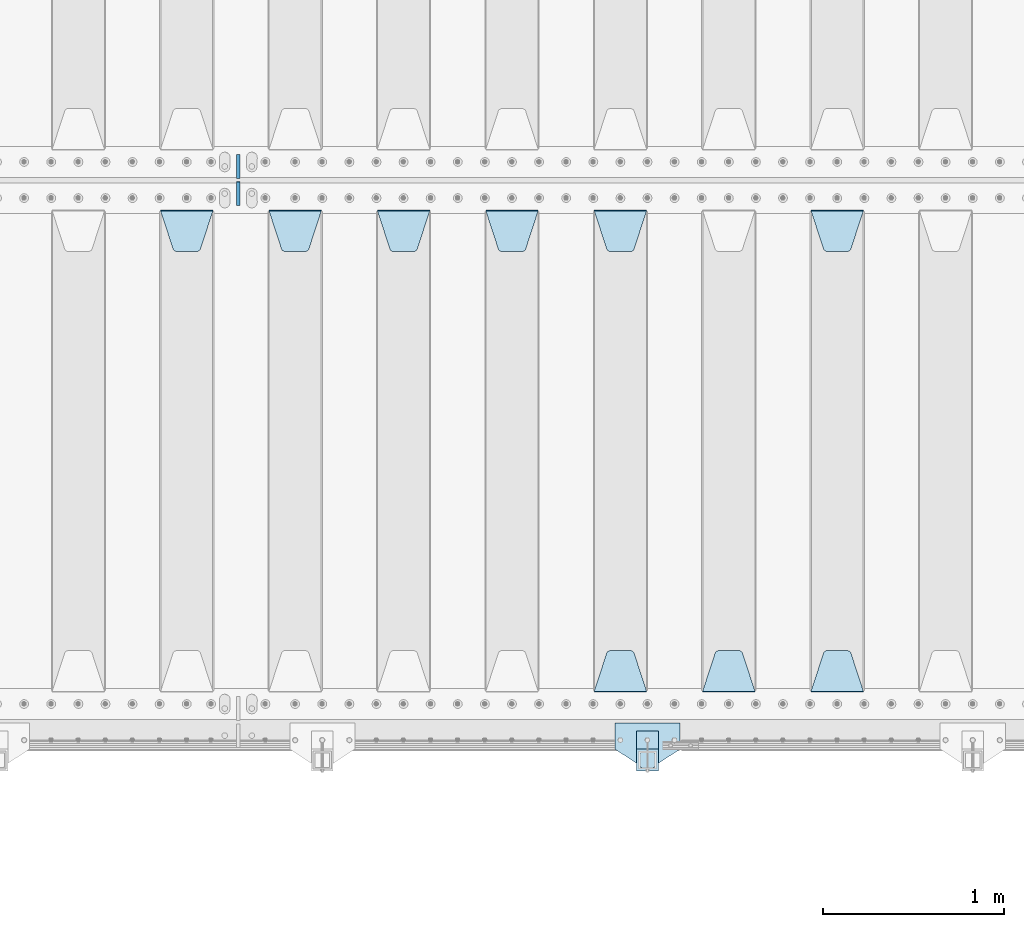
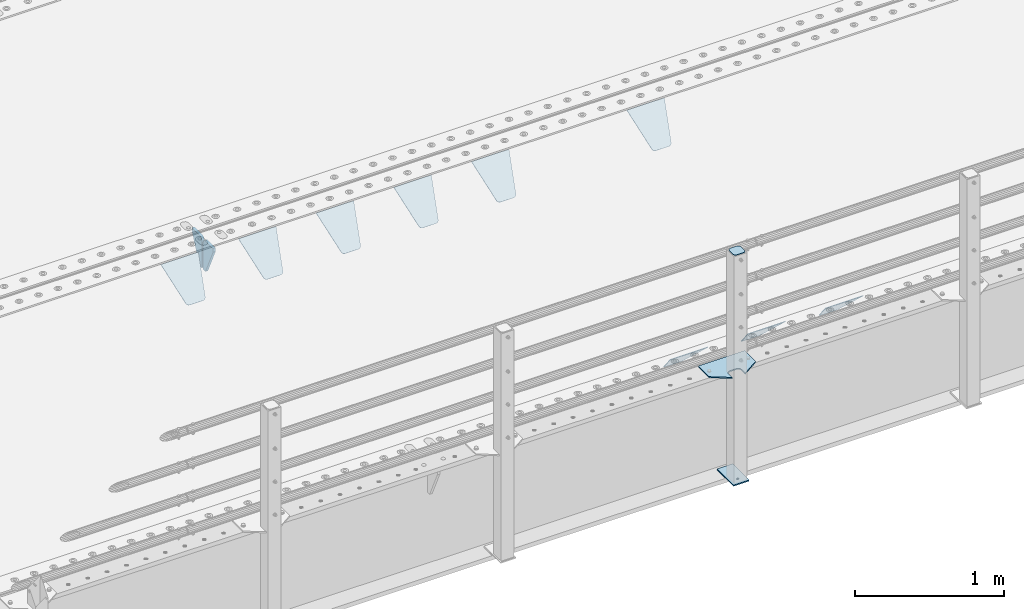
# One storey, part 221 of 270: 15 plates.
"""IFC2X3 building model written with IfcOpenShell, lengths in millimetres."""

from ifc_helpers import new_model, si_unit, frame, origin_with_axes, place, context, subcontext, project, spatial, faceted_brep, material, type_object, element, save


model = new_model("IFC2X3")

# Units and contexts
model_context = context("Model", 3, precision=1e-05, world=origin_with_axes())
body_context = subcontext(model_context, "Body", "Model", "MODEL_VIEW")
ifc_project = project(units=[si_unit("LENGTHUNIT", "METRE", prefix="MILLI"), si_unit("AREAUNIT", "SQUARE_METRE"), si_unit("VOLUMEUNIT", "CUBIC_METRE"), si_unit("MASSUNIT", "GRAM", prefix="KILO"), si_unit("TIMEUNIT", "SECOND"), si_unit("PLANEANGLEUNIT", "RADIAN"), si_unit("SOLIDANGLEUNIT", "STERADIAN"), si_unit("THERMODYNAMICTEMPERATUREUNIT", "DEGREE_CELSIUS"), si_unit("LUMINOUSINTENSITYUNIT", "LUMEN")], contexts=[model_context])

# Site, building, storey
site_placement = place(None, origin_with_axes())
site = spatial("IfcSite", under=ifc_project, at=site_placement, CompositionType="ELEMENT")
building_placement = place(site_placement, origin_with_axes())
building = spatial("IfcBuilding", under=site, at=building_placement, Name="Standard", CompositionType="ELEMENT")
storey_placement = place(building_placement, origin_with_axes())
storey = spatial("IfcBuildingStorey", under=building, at=storey_placement, Name="Undefined", CompositionType="ELEMENT", Elevation=0.0)

# Plates
ifc_material_1 = material(Name="STEEL/S355J2")
plate_type_1 = type_object("IfcPlateType", PredefinedType="NOTDEFINED")
plate_1_placement = place(storey_placement, frame((9730.0, -24005.0, 5.00000000004911), z_axis=(0.0, -1.0, 0.0), x_axis=(-1.0, 0.0, 0.0)))
element("IfcPlate", 1, at=plate_1_placement, inside=storey, type_object=plate_type_1, material=ifc_material_1, context=body_context, shape_type="Brep", body=[
    faceted_brep([(0.0, -5.0, 0.0), (2.31396552408114e-06, -5.0, 145.0), (2.31396552408114e-06, 5.0, 145.0), (0.0, 5.0, 0.0), (130.0, -5.0, 230.0), (130.0, 5.0, 230.0), (130.0, -5.0, 180.0), (130.0, 5.0, 180.0), (130.48036798992, -5.0, 175.122741949597), (130.48036798992, 5.0, 175.122741949597), (131.903011687216, -5.0, 170.432914190873), (131.903011687216, 5.0, 170.432914190873), (134.213259692435, -5.0, 166.11074417451), (134.213259692435, 5.0, 166.11074417451), (137.322330470335, -5.0, 162.322330470337), (137.322330470335, 5.0, 162.322330470337), (141.110744174512, -5.0, 159.213259692437), (141.110744174512, 5.0, 159.213259692437), (145.432914190871, -5.0, 156.903011687218), (145.432914190871, 5.0, 156.903011687218), (150.122741949595, -5.0, 155.48036798992), (150.122741949595, 5.0, 155.48036798992), (155.0, -5.0, 155.0), (155.0, 5.0, 155.0), (205.0, -5.0, 155.0), (205.0, 5.0, 155.0), (209.877258050405, -5.0, 155.48036798992), (209.877258050405, 5.0, 155.48036798992), (214.567085809129, -5.0, 156.903011687218), (214.567085809129, 5.0, 156.903011687218), (218.889255825488, -5.0, 159.213259692437), (218.889255825488, 5.0, 159.213259692437), (222.677669529665, -5.0, 162.322330470337), (222.677669529665, 5.0, 162.322330470337), (225.786740307565, -5.0, 166.11074417451), (225.786740307565, 5.0, 166.11074417451), (228.096988312784, -5.0, 170.432914190873), (228.096988312784, 5.0, 170.432914190873), (229.51963201008, -5.0, 175.122741949597), (229.51963201008, 5.0, 175.122741949597), (230.0, -5.0, 180.0), (230.0, 5.0, 180.0), (230.0, -5.0, 230.0), (230.0, 5.0, 230.0), (360.0, -5.0, 145.0), (360.0, 5.0, 145.0), (360.0, -5.0, -7.27595761418343e-12), (360.0, 5.0, -7.27595761418343e-12)], [[[0, 1, 2, 3]], [[1, 4, 5, 2]], [[4, 6, 7, 5]], [[6, 8, 9, 7]], [[8, 10, 11, 9]], [[10, 12, 13, 11]], [[12, 14, 15, 13]], [[14, 16, 17, 15]], [[16, 18, 19, 17]], [[18, 20, 21, 19]], [[20, 22, 23, 21]], [[22, 24, 25, 23]], [[24, 26, 27, 25]], [[26, 28, 29, 27]], [[28, 30, 31, 29]], [[30, 32, 33, 31]], [[32, 34, 35, 33]], [[34, 36, 37, 35]], [[36, 38, 39, 37]], [[38, 40, 41, 39]], [[40, 42, 43, 41]], [[42, 44, 45, 43]], [[44, 46, 47, 45]], [[46, 0, 3, 47]], [[5, 7, 9, 11, 13, 15, 17, 19, 21, 23, 25, 27, 29, 31, 33, 35, 37, 39, 41, 43, 45, 47, 3, 2]], [[46, 44, 42, 40, 38, 36, 34, 32, 30, 28, 26, 24, 22, 20, 18, 16, 14, 12, 10, 8, 6, 4, 1, 0]]]),
])
plate_type_2 = type_object("IfcPlateType", PredefinedType="NOTDEFINED")
plate_2_placement = place(storey_placement, frame((9609.99999999986, -24050.0000000002, -850.000000000002), z_axis=(0.0, -1.0, 0.0), x_axis=(-1.0, 0.0, 0.0)))
element("IfcPlate", 2, at=plate_2_placement, inside=storey, type_object=plate_type_2, material=ifc_material_1, context=body_context, shape_type="Brep", body=[
    faceted_brep([(53.6360389691836, -5.0, 176.363961030471), (53.6360389691836, 5.0, 176.363961030471), (59.9999999998618, 5.0, 178.999999999793), (59.9999999998618, -5.0, 178.999999999793), (66.3639610305399, 5.0, 176.363961030471), (66.3639610305399, -5.0, 176.363961030471), (68.9999999998618, 5.0, 169.999999999793), (68.9999999998618, -5.0, 169.999999999793), (66.3639610305399, 5.0, 163.636038969114), (66.3639610305399, -5.0, 163.636038969114), (59.9999999998618, 5.0, 160.999999999793), (59.9999999998618, -5.0, 160.999999999793), (53.6360389691836, 5.0, 163.636038969114), (53.6360389691836, -5.0, 163.636038969114), (50.9999999998618, 5.0, 169.999999999793), (50.9999999998618, -5.0, 169.999999999793), (120.0, -5.0, 0.0), (120.0, -5.0, 220.0), (0.0, -5.0, 220.0), (0.0, -5.0, 0.0), (0.0, 5.0, 0.0), (120.0, 5.0, 0.0), (120.0, 5.0, 220.0), (0.0, 5.0, 220.0)], [[[0, 1, 2, 3]], [[3, 2, 4, 5]], [[5, 4, 6, 7]], [[7, 6, 8, 9]], [[9, 8, 10, 11]], [[11, 10, 12, 13]], [[13, 12, 14, 15]], [[15, 14, 1, 0]], [[16, 17, 18, 19], [11, 13, 15, 0, 3, 5, 7, 9]], [[16, 19, 20, 21]], [[17, 16, 21, 22]], [[18, 17, 22, 23]], [[19, 18, 23, 20]], [[22, 21, 20, 23], [2, 1, 14, 12, 10, 8, 6, 4]]]),
])
plate_type_3 = type_object("IfcPlateType", PredefinedType="NOTDEFINED")
plate_3_placement = place(storey_placement, frame((9505.99999999987, -24166.0000000002, 1012.50000000001), z_axis=(0.0, -1.0, 0.0), x_axis=(1.0, 0.0, 0.0)))
element("IfcPlate", 3, at=plate_3_placement, inside=storey, type_object=plate_type_3, material=ifc_material_1, context=body_context, shape_type="Brep", body=[
    faceted_brep([(0.0, -2.5, 19.0), (0.0, -2.5, 69.0), (0.0, 2.5, 69.0), (0.0, 2.5, 19.0), (0.476369668544066, -2.5, 73.2278977451697), (0.476369668544066, 2.5, 73.2278977451697), (1.88159150985302, -2.5, 77.2437910432327), (1.88159150985302, 2.5, 77.2437910432327), (4.14520183310742, -2.5, 80.8463062353167), (4.14520183310742, 2.5, 80.8463062353167), (7.15369376468516, -2.5, 83.8547981668926), (7.15369376468516, 2.5, 83.8547981668926), (10.7562089567655, -2.5, 86.1184084901452), (10.7562089567655, 2.5, 86.1184084901452), (14.7721022548285, -2.5, 87.5236303314541), (14.7721022548285, 2.5, 87.5236303314541), (19.0, -2.5, 88.0), (19.0, 2.5, 88.0), (69.0, -2.5, 88.0), (69.0, 2.5, 88.0), (73.2278977451715, -2.5, 87.5236303314541), (73.2278977451715, 2.5, 87.5236303314541), (77.2437910432345, -2.5, 86.1184084901452), (77.2437910432345, 2.5, 86.1184084901452), (80.8463062353148, -2.5, 83.8547981668926), (80.8463062353148, 2.5, 83.8547981668926), (83.8547981668926, -2.5, 80.8463062353167), (83.8547981668926, 2.5, 80.8463062353167), (86.118408490147, -2.5, 77.2437910432345), (86.118408490147, 2.5, 77.2437910432345), (87.5236303314559, -2.5, 73.2278977451697), (87.5236303314559, 2.5, 73.2278977451697), (88.0, -2.5, 69.0), (88.0, 2.5, 69.0), (88.0, -2.5, 19.0), (88.0, 2.5, 19.0), (87.5236303314559, -2.5, 14.7721022548303), (87.5236303314559, 2.5, 14.7721022548303), (86.118408490147, -2.5, 10.7562089567673), (86.118408490147, 2.5, 10.7562089567673), (83.8547981668926, -2.5, 7.15369376468334), (83.8547981668926, 2.5, 7.15369376468334), (80.8463062353148, -2.5, 4.14520183310742), (80.8463062353148, 2.5, 4.14520183310742), (77.2437910432345, -2.5, 1.88159150985484), (77.2437910432345, 2.5, 1.88159150985484), (73.2278977451715, -2.5, 0.476369668545885), (73.2278977451715, 2.5, 0.476369668545885), (69.0, -2.5, 0.0), (69.0, 2.5, 0.0), (19.0, -2.5, 0.0), (19.0, 2.5, 0.0), (14.7721022548285, -2.5, 0.476369668545885), (14.7721022548285, 2.5, 0.476369668545885), (10.7562089567655, -2.5, 1.88159150985484), (10.7562089567655, 2.5, 1.88159150985484), (7.15369376468516, -2.5, 4.14520183310742), (7.15369376468516, 2.5, 4.14520183310742), (4.14520183310742, -2.5, 7.15369376468334), (4.14520183310742, 2.5, 7.15369376468334), (1.88159150985302, -2.5, 10.7562089567673), (1.88159150985302, 2.5, 10.7562089567673), (0.476369668544066, -2.5, 14.7721022548303), (0.476369668544066, 2.5, 14.7721022548303)], [[[0, 1, 2, 3]], [[1, 4, 5, 2]], [[4, 6, 7, 5]], [[6, 8, 9, 7]], [[8, 10, 11, 9]], [[10, 12, 13, 11]], [[12, 14, 15, 13]], [[14, 16, 17, 15]], [[16, 18, 19, 17]], [[18, 20, 21, 19]], [[20, 22, 23, 21]], [[22, 24, 25, 23]], [[24, 26, 27, 25]], [[26, 28, 29, 27]], [[28, 30, 31, 29]], [[30, 32, 33, 31]], [[32, 34, 35, 33]], [[34, 36, 37, 35]], [[36, 38, 39, 37]], [[38, 40, 41, 39]], [[40, 42, 43, 41]], [[42, 44, 45, 43]], [[44, 46, 47, 45]], [[46, 48, 49, 47]], [[48, 50, 51, 49]], [[50, 52, 53, 51]], [[52, 54, 55, 53]], [[54, 56, 57, 55]], [[56, 58, 59, 57]], [[58, 60, 61, 59]], [[60, 62, 63, 61]], [[62, 0, 3, 63]], [[5, 7, 9, 11, 13, 15, 17, 19, 21, 23, 25, 27, 29, 31, 33, 35, 37, 39, 41, 43, 45, 47, 49, 51, 53, 55, 57, 59, 61, 63, 3, 2]], [[62, 60, 58, 56, 54, 52, 50, 48, 46, 44, 42, 40, 38, 36, 34, 32, 30, 28, 26, 24, 22, 20, 18, 16, 14, 12, 10, 8, 6, 4, 1, 0]]]),
])
plate_type_4 = type_object("IfcPlateType", PredefinedType="NOTDEFINED")
plate_4_placement = place(storey_placement, frame((9609.99999999986, -24050.0000000002, -857.500000000002), z_axis=(0.0, -1.0, 0.0), x_axis=(-1.0, 0.0, 0.0)))
element("IfcPlate", 4, at=plate_4_placement, inside=storey, type_object=plate_type_4, material=ifc_material_1, context=body_context, shape_type="Brep", body=[
    faceted_brep([(0.0, -2.5, 0.0), (0.0, -2.5, 100.0), (0.0, 2.5, 100.0), (0.0, 2.5, 0.0), (120.0, -2.5, 100.0), (120.0, 2.5, 100.0), (120.0, -2.5, 0.0), (120.0, 2.5, 0.0)], [[[0, 1, 2, 3]], [[1, 4, 5, 2]], [[4, 6, 7, 5]], [[6, 0, 3, 7]], [[5, 7, 3, 2]], [[6, 4, 1, 0]]]),
])
ifc_material_2 = material(Name="STEEL/S355N")
plate_type_5 = type_object("IfcPlateType", PredefinedType="NOTDEFINED")
plate_5_placement = place(storey_placement, frame((10455.0, -21168.232233044, -1.76776695296576), z_axis=(0.0, -0.707106781186548, -0.707106781186547), x_axis=(1.0, 0.0, 0.0)))
element("IfcPlate", 5, at=plate_5_placement, inside=storey, type_object=plate_type_5, material=ifc_material_2, context=body_context, shape_type="Brep", body=[
    faceted_brep([(0.0, -2.5, 0.0), (69.345504679477, -2.5, 300.171731424831), (69.345504679477, 2.5, 300.171731424831), (0.0, 2.5, 0.0), (70.9274061199576, -2.5, 304.8974424154), (70.9274061199576, 2.5, 304.8974424154), (73.3818627772307, -2.49999999999818, 309.234538108527), (73.3818627772307, 2.50000000000182, 309.234538108527), (76.6187032999551, -2.5, 313.023683126103), (76.6187032999551, 2.5, 313.023683126103), (80.5190132704993, -2.5, 316.125672595372), (80.5190132704993, 2.50000000000182, 316.125672595372), (84.9395038596849, -2.49999999999818, 318.426546230476), (84.9395038596849, 2.5, 318.426546230476), (89.7177759439219, -2.49999999999818, 319.841774983275), (89.7177759439219, 2.50000000000182, 319.841774983275), (94.678286292652, -2.5, 320.319366455078), (94.678286292652, 2.5, 320.319366455078), (195.321713707348, -2.5, 320.319366455078), (195.321713707348, 2.5, 320.319366455078), (200.282224056078, -2.49999999999818, 319.841774983275), (200.282224056078, 2.50000000000182, 319.841774983275), (205.060496140315, -2.5, 318.426546230476), (205.060496140315, 2.5, 318.426546230476), (209.480986729501, -2.5, 316.12567259537), (209.480986729501, 2.50000000000182, 316.12567259537), (213.381296700045, -2.5, 313.023683126103), (213.381296700045, 2.5, 313.023683126103), (216.618137222769, -2.49999999999818, 309.234538108525), (216.618137222769, 2.50000000000182, 309.234538108527), (219.072593880042, -2.49999999999818, 304.897442415398), (219.072593880042, 2.50000000000182, 304.897442415397), (220.654495320523, -2.5, 300.171731424831), (220.654495320523, 2.5, 300.171731424831), (290.0, -2.49999999999818, 0.0), (290.0, 2.5, 0.0)], [[[0, 1, 2, 3]], [[1, 4, 5, 2]], [[4, 6, 7, 5]], [[6, 8, 9, 7]], [[8, 10, 11, 9]], [[10, 12, 13, 11]], [[12, 14, 15, 13]], [[14, 16, 17, 15]], [[16, 18, 19, 17]], [[18, 20, 21, 19]], [[20, 22, 23, 21]], [[22, 24, 25, 23]], [[24, 26, 27, 25]], [[26, 28, 29, 27]], [[28, 30, 31, 29]], [[30, 32, 33, 31]], [[32, 34, 35, 33]], [[34, 0, 3, 35]], [[5, 7, 9, 11, 13, 15, 17, 19, 21, 23, 25, 27, 29, 31, 33, 35, 3, 2]], [[34, 32, 30, 28, 26, 24, 22, 20, 18, 16, 14, 12, 10, 8, 6, 4, 1, 0]]]),
])
plate_6_placement = place(storey_placement, frame((10745.0, -23831.767766953, -1.76776695296758), z_axis=(0.0, 0.707106781186547, -0.707106781186548), x_axis=(-1.0, 0.0, 0.0)))
element("IfcPlate", 6, at=plate_6_placement, inside=storey, type_object=plate_type_5, material=ifc_material_2, context=body_context, shape_type="Brep", body=[
    faceted_brep([(0.0, -2.5, 0.0), (69.345504679477, -2.5, 300.171731424831), (69.345504679477, 2.5, 300.171731424831), (0.0, 2.5, 0.0), (70.9274061199576, -2.5, 304.8974424154), (70.9274061199576, 2.5, 304.8974424154), (73.3818627772307, -2.49999999999818, 309.234538108527), (73.3818627772307, 2.50000000000182, 309.234538108527), (76.6187032999551, -2.5, 313.023683126103), (76.6187032999551, 2.5, 313.023683126103), (80.5190132704993, -2.5, 316.125672595372), (80.5190132704993, 2.50000000000182, 316.125672595372), (84.9395038596849, -2.49999999999818, 318.426546230476), (84.9395038596849, 2.5, 318.426546230476), (89.7177759439219, -2.49999999999818, 319.841774983275), (89.7177759439219, 2.50000000000182, 319.841774983275), (94.678286292652, -2.5, 320.319366455078), (94.678286292652, 2.5, 320.319366455078), (195.321713707348, -2.5, 320.319366455078), (195.321713707348, 2.5, 320.319366455078), (200.282224056078, -2.49999999999818, 319.841774983275), (200.282224056078, 2.50000000000182, 319.841774983275), (205.060496140315, -2.5, 318.426546230476), (205.060496140315, 2.5, 318.426546230476), (209.480986729501, -2.5, 316.12567259537), (209.480986729501, 2.50000000000182, 316.12567259537), (213.381296700045, -2.5, 313.023683126103), (213.381296700045, 2.5, 313.023683126103), (216.618137222769, -2.49999999999818, 309.234538108525), (216.618137222769, 2.50000000000182, 309.234538108527), (219.072593880042, -2.49999999999818, 304.897442415398), (219.072593880042, 2.50000000000182, 304.897442415397), (220.654495320523, -2.5, 300.171731424831), (220.654495320523, 2.5, 300.171731424831), (290.0, -2.49999999999818, 0.0), (290.0, 2.5, 0.0)], [[[0, 1, 2, 3]], [[1, 4, 5, 2]], [[4, 6, 7, 5]], [[6, 8, 9, 7]], [[8, 10, 11, 9]], [[10, 12, 13, 11]], [[12, 14, 15, 13]], [[14, 16, 17, 15]], [[16, 18, 19, 17]], [[18, 20, 21, 19]], [[20, 22, 23, 21]], [[22, 24, 25, 23]], [[24, 26, 27, 25]], [[26, 28, 29, 27]], [[28, 30, 31, 29]], [[30, 32, 33, 31]], [[32, 34, 35, 33]], [[34, 0, 3, 35]], [[5, 7, 9, 11, 13, 15, 17, 19, 21, 23, 25, 27, 29, 31, 33, 35, 3, 2]], [[34, 32, 30, 28, 26, 24, 22, 20, 18, 16, 14, 12, 10, 8, 6, 4, 1, 0]]]),
])
plate_7_placement = place(storey_placement, frame((10145.0, -23831.767766953, -1.76776695296758), z_axis=(0.0, 0.707106781186547, -0.707106781186548), x_axis=(-1.0, 0.0, 0.0)))
element("IfcPlate", 7, at=plate_7_placement, inside=storey, type_object=plate_type_5, material=ifc_material_2, context=body_context, shape_type="Brep", body=[
    faceted_brep([(0.0, -2.5, 0.0), (69.345504679477, -2.5, 300.171731424831), (69.345504679477, 2.5, 300.171731424831), (0.0, 2.5, 0.0), (70.9274061199576, -2.5, 304.8974424154), (70.9274061199576, 2.5, 304.8974424154), (73.3818627772307, -2.49999999999818, 309.234538108527), (73.3818627772307, 2.50000000000182, 309.234538108527), (76.6187032999551, -2.5, 313.023683126103), (76.6187032999551, 2.5, 313.023683126103), (80.5190132704993, -2.5, 316.125672595372), (80.5190132704993, 2.50000000000182, 316.125672595372), (84.9395038596849, -2.49999999999818, 318.426546230476), (84.9395038596849, 2.5, 318.426546230476), (89.7177759439219, -2.49999999999818, 319.841774983275), (89.7177759439219, 2.50000000000182, 319.841774983275), (94.678286292652, -2.5, 320.319366455078), (94.678286292652, 2.5, 320.319366455078), (195.321713707348, -2.5, 320.319366455078), (195.321713707348, 2.5, 320.319366455078), (200.282224056078, -2.49999999999818, 319.841774983275), (200.282224056078, 2.50000000000182, 319.841774983275), (205.060496140315, -2.5, 318.426546230476), (205.060496140315, 2.5, 318.426546230476), (209.480986729501, -2.5, 316.12567259537), (209.480986729501, 2.50000000000182, 316.12567259537), (213.381296700045, -2.5, 313.023683126103), (213.381296700045, 2.5, 313.023683126103), (216.618137222769, -2.49999999999818, 309.234538108525), (216.618137222769, 2.50000000000182, 309.234538108527), (219.072593880042, -2.49999999999818, 304.897442415398), (219.072593880042, 2.50000000000182, 304.897442415397), (220.654495320523, -2.5, 300.171731424831), (220.654495320523, 2.5, 300.171731424831), (290.0, -2.49999999999818, 0.0), (290.0, 2.5, 0.0)], [[[0, 1, 2, 3]], [[1, 4, 5, 2]], [[4, 6, 7, 5]], [[6, 8, 9, 7]], [[8, 10, 11, 9]], [[10, 12, 13, 11]], [[12, 14, 15, 13]], [[14, 16, 17, 15]], [[16, 18, 19, 17]], [[18, 20, 21, 19]], [[20, 22, 23, 21]], [[22, 24, 25, 23]], [[24, 26, 27, 25]], [[26, 28, 29, 27]], [[28, 30, 31, 29]], [[30, 32, 33, 31]], [[32, 34, 35, 33]], [[34, 0, 3, 35]], [[5, 7, 9, 11, 13, 15, 17, 19, 21, 23, 25, 27, 29, 31, 33, 35, 3, 2]], [[34, 32, 30, 28, 26, 24, 22, 20, 18, 16, 14, 12, 10, 8, 6, 4, 1, 0]]]),
])
plate_8_placement = place(storey_placement, frame((9255.0, -21168.232233044, -1.76776695296576), z_axis=(0.0, -0.707106781186548, -0.707106781186547), x_axis=(1.0, 0.0, 0.0)))
element("IfcPlate", 8, at=plate_8_placement, inside=storey, type_object=plate_type_5, material=ifc_material_2, context=body_context, shape_type="Brep", body=[
    faceted_brep([(0.0, -2.5, 0.0), (69.345504679477, -2.5, 300.171731424831), (69.345504679477, 2.5, 300.171731424831), (0.0, 2.5, 0.0), (70.9274061199576, -2.5, 304.8974424154), (70.9274061199576, 2.5, 304.8974424154), (73.3818627772307, -2.49999999999818, 309.234538108527), (73.3818627772307, 2.50000000000182, 309.234538108527), (76.6187032999551, -2.5, 313.023683126103), (76.6187032999551, 2.5, 313.023683126103), (80.5190132704993, -2.5, 316.125672595372), (80.5190132704993, 2.50000000000182, 316.125672595372), (84.9395038596849, -2.49999999999818, 318.426546230476), (84.9395038596849, 2.5, 318.426546230476), (89.7177759439219, -2.49999999999818, 319.841774983275), (89.7177759439219, 2.50000000000182, 319.841774983275), (94.678286292652, -2.5, 320.319366455078), (94.678286292652, 2.5, 320.319366455078), (195.321713707348, -2.5, 320.319366455078), (195.321713707348, 2.5, 320.319366455078), (200.282224056078, -2.49999999999818, 319.841774983275), (200.282224056078, 2.50000000000182, 319.841774983275), (205.060496140315, -2.5, 318.426546230476), (205.060496140315, 2.5, 318.426546230476), (209.480986729501, -2.5, 316.12567259537), (209.480986729501, 2.50000000000182, 316.12567259537), (213.381296700045, -2.5, 313.023683126103), (213.381296700045, 2.5, 313.023683126103), (216.618137222769, -2.49999999999818, 309.234538108525), (216.618137222769, 2.50000000000182, 309.234538108527), (219.072593880042, -2.49999999999818, 304.897442415398), (219.072593880042, 2.50000000000182, 304.897442415397), (220.654495320523, -2.5, 300.171731424831), (220.654495320523, 2.5, 300.171731424831), (290.0, -2.49999999999818, 0.0), (290.0, 2.5, 0.0)], [[[0, 1, 2, 3]], [[1, 4, 5, 2]], [[4, 6, 7, 5]], [[6, 8, 9, 7]], [[8, 10, 11, 9]], [[10, 12, 13, 11]], [[12, 14, 15, 13]], [[14, 16, 17, 15]], [[16, 18, 19, 17]], [[18, 20, 21, 19]], [[20, 22, 23, 21]], [[22, 24, 25, 23]], [[24, 26, 27, 25]], [[26, 28, 29, 27]], [[28, 30, 31, 29]], [[30, 32, 33, 31]], [[32, 34, 35, 33]], [[34, 0, 3, 35]], [[5, 7, 9, 11, 13, 15, 17, 19, 21, 23, 25, 27, 29, 31, 33, 35, 3, 2]], [[34, 32, 30, 28, 26, 24, 22, 20, 18, 16, 14, 12, 10, 8, 6, 4, 1, 0]]]),
])
plate_9_placement = place(storey_placement, frame((9545.0, -23831.767766953, -1.76776695296758), z_axis=(0.0, 0.707106781186547, -0.707106781186548), x_axis=(-1.0, 0.0, 0.0)))
element("IfcPlate", 9, at=plate_9_placement, inside=storey, type_object=plate_type_5, material=ifc_material_2, context=body_context, shape_type="Brep", body=[
    faceted_brep([(0.0, -2.5, 0.0), (69.345504679477, -2.5, 300.171731424831), (69.345504679477, 2.5, 300.171731424831), (0.0, 2.5, 0.0), (70.9274061199576, -2.5, 304.8974424154), (70.9274061199576, 2.5, 304.8974424154), (73.3818627772307, -2.49999999999818, 309.234538108527), (73.3818627772307, 2.50000000000182, 309.234538108527), (76.6187032999551, -2.5, 313.023683126103), (76.6187032999551, 2.5, 313.023683126103), (80.5190132704993, -2.5, 316.125672595372), (80.5190132704993, 2.50000000000182, 316.125672595372), (84.9395038596849, -2.49999999999818, 318.426546230476), (84.9395038596849, 2.5, 318.426546230476), (89.7177759439219, -2.49999999999818, 319.841774983275), (89.7177759439219, 2.50000000000182, 319.841774983275), (94.678286292652, -2.5, 320.319366455078), (94.678286292652, 2.5, 320.319366455078), (195.321713707348, -2.5, 320.319366455078), (195.321713707348, 2.5, 320.319366455078), (200.282224056078, -2.49999999999818, 319.841774983275), (200.282224056078, 2.50000000000182, 319.841774983275), (205.060496140315, -2.5, 318.426546230476), (205.060496140315, 2.5, 318.426546230476), (209.480986729501, -2.5, 316.12567259537), (209.480986729501, 2.50000000000182, 316.12567259537), (213.381296700045, -2.5, 313.023683126103), (213.381296700045, 2.5, 313.023683126103), (216.618137222769, -2.49999999999818, 309.234538108525), (216.618137222769, 2.50000000000182, 309.234538108527), (219.072593880042, -2.49999999999818, 304.897442415398), (219.072593880042, 2.50000000000182, 304.897442415397), (220.654495320523, -2.5, 300.171731424831), (220.654495320523, 2.5, 300.171731424831), (290.0, -2.49999999999818, 0.0), (290.0, 2.5, 0.0)], [[[0, 1, 2, 3]], [[1, 4, 5, 2]], [[4, 6, 7, 5]], [[6, 8, 9, 7]], [[8, 10, 11, 9]], [[10, 12, 13, 11]], [[12, 14, 15, 13]], [[14, 16, 17, 15]], [[16, 18, 19, 17]], [[18, 20, 21, 19]], [[20, 22, 23, 21]], [[22, 24, 25, 23]], [[24, 26, 27, 25]], [[26, 28, 29, 27]], [[28, 30, 31, 29]], [[30, 32, 33, 31]], [[32, 34, 35, 33]], [[34, 0, 3, 35]], [[5, 7, 9, 11, 13, 15, 17, 19, 21, 23, 25, 27, 29, 31, 33, 35, 3, 2]], [[34, 32, 30, 28, 26, 24, 22, 20, 18, 16, 14, 12, 10, 8, 6, 4, 1, 0]]]),
])
plate_10_placement = place(storey_placement, frame((8655.0, -21168.232233044, -1.76776695296576), z_axis=(0.0, -0.707106781186548, -0.707106781186547), x_axis=(1.0, 0.0, 0.0)))
element("IfcPlate", 10, at=plate_10_placement, inside=storey, type_object=plate_type_5, material=ifc_material_2, context=body_context, shape_type="Brep", body=[
    faceted_brep([(0.0, -2.5, 0.0), (69.345504679477, -2.5, 300.171731424831), (69.345504679477, 2.5, 300.171731424831), (0.0, 2.5, 0.0), (70.9274061199576, -2.5, 304.8974424154), (70.9274061199576, 2.5, 304.8974424154), (73.3818627772307, -2.49999999999818, 309.234538108527), (73.3818627772307, 2.50000000000182, 309.234538108527), (76.6187032999551, -2.5, 313.023683126103), (76.6187032999551, 2.5, 313.023683126103), (80.5190132704993, -2.5, 316.125672595372), (80.5190132704993, 2.50000000000182, 316.125672595372), (84.9395038596849, -2.49999999999818, 318.426546230476), (84.9395038596849, 2.5, 318.426546230476), (89.7177759439219, -2.49999999999818, 319.841774983275), (89.7177759439219, 2.50000000000182, 319.841774983275), (94.678286292652, -2.5, 320.319366455078), (94.678286292652, 2.5, 320.319366455078), (195.321713707348, -2.5, 320.319366455078), (195.321713707348, 2.5, 320.319366455078), (200.282224056078, -2.49999999999818, 319.841774983275), (200.282224056078, 2.50000000000182, 319.841774983275), (205.060496140315, -2.5, 318.426546230476), (205.060496140315, 2.5, 318.426546230476), (209.480986729501, -2.5, 316.12567259537), (209.480986729501, 2.50000000000182, 316.12567259537), (213.381296700045, -2.5, 313.023683126103), (213.381296700045, 2.5, 313.023683126103), (216.618137222769, -2.49999999999818, 309.234538108525), (216.618137222769, 2.50000000000182, 309.234538108527), (219.072593880042, -2.49999999999818, 304.897442415398), (219.072593880042, 2.50000000000182, 304.897442415397), (220.654495320523, -2.5, 300.171731424831), (220.654495320523, 2.5, 300.171731424831), (290.0, -2.49999999999818, 0.0), (290.0, 2.5, 0.0)], [[[0, 1, 2, 3]], [[1, 4, 5, 2]], [[4, 6, 7, 5]], [[6, 8, 9, 7]], [[8, 10, 11, 9]], [[10, 12, 13, 11]], [[12, 14, 15, 13]], [[14, 16, 17, 15]], [[16, 18, 19, 17]], [[18, 20, 21, 19]], [[20, 22, 23, 21]], [[22, 24, 25, 23]], [[24, 26, 27, 25]], [[26, 28, 29, 27]], [[28, 30, 31, 29]], [[30, 32, 33, 31]], [[32, 34, 35, 33]], [[34, 0, 3, 35]], [[5, 7, 9, 11, 13, 15, 17, 19, 21, 23, 25, 27, 29, 31, 33, 35, 3, 2]], [[34, 32, 30, 28, 26, 24, 22, 20, 18, 16, 14, 12, 10, 8, 6, 4, 1, 0]]]),
])
plate_11_placement = place(storey_placement, frame((8055.0, -21168.232233044, -1.76776695296576), z_axis=(0.0, -0.707106781186548, -0.707106781186547), x_axis=(1.0, 0.0, 0.0)))
element("IfcPlate", 11, at=plate_11_placement, inside=storey, type_object=plate_type_5, material=ifc_material_2, context=body_context, shape_type="Brep", body=[
    faceted_brep([(0.0, -2.5, 0.0), (69.345504679477, -2.5, 300.171731424831), (69.345504679477, 2.5, 300.171731424831), (0.0, 2.5, 0.0), (70.9274061199576, -2.5, 304.8974424154), (70.9274061199576, 2.5, 304.8974424154), (73.3818627772307, -2.49999999999818, 309.234538108527), (73.3818627772307, 2.50000000000182, 309.234538108527), (76.6187032999551, -2.5, 313.023683126103), (76.6187032999551, 2.5, 313.023683126103), (80.5190132704993, -2.5, 316.125672595372), (80.5190132704993, 2.50000000000182, 316.125672595372), (84.9395038596849, -2.49999999999818, 318.426546230476), (84.9395038596849, 2.5, 318.426546230476), (89.7177759439219, -2.49999999999818, 319.841774983275), (89.7177759439219, 2.50000000000182, 319.841774983275), (94.678286292652, -2.5, 320.319366455078), (94.678286292652, 2.5, 320.319366455078), (195.321713707348, -2.5, 320.319366455078), (195.321713707348, 2.5, 320.319366455078), (200.282224056078, -2.49999999999818, 319.841774983275), (200.282224056078, 2.50000000000182, 319.841774983275), (205.060496140315, -2.5, 318.426546230476), (205.060496140315, 2.5, 318.426546230476), (209.480986729501, -2.5, 316.12567259537), (209.480986729501, 2.50000000000182, 316.12567259537), (213.381296700045, -2.5, 313.023683126103), (213.381296700045, 2.5, 313.023683126103), (216.618137222769, -2.49999999999818, 309.234538108525), (216.618137222769, 2.50000000000182, 309.234538108527), (219.072593880042, -2.49999999999818, 304.897442415398), (219.072593880042, 2.50000000000182, 304.897442415397), (220.654495320523, -2.5, 300.171731424831), (220.654495320523, 2.5, 300.171731424831), (290.0, -2.49999999999818, 0.0), (290.0, 2.5, 0.0)], [[[0, 1, 2, 3]], [[1, 4, 5, 2]], [[4, 6, 7, 5]], [[6, 8, 9, 7]], [[8, 10, 11, 9]], [[10, 12, 13, 11]], [[12, 14, 15, 13]], [[14, 16, 17, 15]], [[16, 18, 19, 17]], [[18, 20, 21, 19]], [[20, 22, 23, 21]], [[22, 24, 25, 23]], [[24, 26, 27, 25]], [[26, 28, 29, 27]], [[28, 30, 31, 29]], [[30, 32, 33, 31]], [[32, 34, 35, 33]], [[34, 0, 3, 35]], [[5, 7, 9, 11, 13, 15, 17, 19, 21, 23, 25, 27, 29, 31, 33, 35, 3, 2]], [[34, 32, 30, 28, 26, 24, 22, 20, 18, 16, 14, 12, 10, 8, 6, 4, 1, 0]]]),
])
plate_12_placement = place(storey_placement, frame((7455.0, -21168.232233044, -1.76776695296576), z_axis=(0.0, -0.707106781186548, -0.707106781186547), x_axis=(1.0, 0.0, 0.0)))
element("IfcPlate", 12, at=plate_12_placement, inside=storey, type_object=plate_type_5, material=ifc_material_2, context=body_context, shape_type="Brep", body=[
    faceted_brep([(0.0, -2.5, 0.0), (69.345504679477, -2.5, 300.171731424831), (69.345504679477, 2.5, 300.171731424831), (0.0, 2.5, 0.0), (70.9274061199576, -2.5, 304.8974424154), (70.9274061199576, 2.5, 304.8974424154), (73.3818627772307, -2.49999999999818, 309.234538108527), (73.3818627772307, 2.50000000000182, 309.234538108527), (76.6187032999551, -2.5, 313.023683126103), (76.6187032999551, 2.5, 313.023683126103), (80.5190132704993, -2.5, 316.125672595372), (80.5190132704993, 2.50000000000182, 316.125672595372), (84.9395038596849, -2.49999999999818, 318.426546230476), (84.9395038596849, 2.5, 318.426546230476), (89.7177759439219, -2.49999999999818, 319.841774983275), (89.7177759439219, 2.50000000000182, 319.841774983275), (94.678286292652, -2.5, 320.319366455078), (94.678286292652, 2.5, 320.319366455078), (195.321713707348, -2.5, 320.319366455078), (195.321713707348, 2.5, 320.319366455078), (200.282224056078, -2.49999999999818, 319.841774983275), (200.282224056078, 2.50000000000182, 319.841774983275), (205.060496140315, -2.5, 318.426546230476), (205.060496140315, 2.5, 318.426546230476), (209.480986729501, -2.5, 316.12567259537), (209.480986729501, 2.50000000000182, 316.12567259537), (213.381296700045, -2.5, 313.023683126103), (213.381296700045, 2.5, 313.023683126103), (216.618137222769, -2.49999999999818, 309.234538108525), (216.618137222769, 2.50000000000182, 309.234538108527), (219.072593880042, -2.49999999999818, 304.897442415398), (219.072593880042, 2.50000000000182, 304.897442415397), (220.654495320523, -2.5, 300.171731424831), (220.654495320523, 2.5, 300.171731424831), (290.0, -2.49999999999818, 0.0), (290.0, 2.5, 0.0)], [[[0, 1, 2, 3]], [[1, 4, 5, 2]], [[4, 6, 7, 5]], [[6, 8, 9, 7]], [[8, 10, 11, 9]], [[10, 12, 13, 11]], [[12, 14, 15, 13]], [[14, 16, 17, 15]], [[16, 18, 19, 17]], [[18, 20, 21, 19]], [[20, 22, 23, 21]], [[22, 24, 25, 23]], [[24, 26, 27, 25]], [[26, 28, 29, 27]], [[28, 30, 31, 29]], [[30, 32, 33, 31]], [[32, 34, 35, 33]], [[34, 0, 3, 35]], [[5, 7, 9, 11, 13, 15, 17, 19, 21, 23, 25, 27, 29, 31, 33, 35, 3, 2]], [[34, 32, 30, 28, 26, 24, 22, 20, 18, 16, 14, 12, 10, 8, 6, 4, 1, 0]]]),
])
plate_13_placement = place(storey_placement, frame((6855.0, -21168.232233044, -1.76776695296576), z_axis=(0.0, -0.707106781186548, -0.707106781186547), x_axis=(1.0, 0.0, 0.0)))
element("IfcPlate", 13, at=plate_13_placement, inside=storey, type_object=plate_type_5, material=ifc_material_2, context=body_context, shape_type="Brep", body=[
    faceted_brep([(0.0, -2.5, 0.0), (69.345504679477, -2.5, 300.171731424831), (69.345504679477, 2.5, 300.171731424831), (0.0, 2.5, 0.0), (70.9274061199576, -2.5, 304.8974424154), (70.9274061199576, 2.5, 304.8974424154), (73.3818627772307, -2.49999999999818, 309.234538108527), (73.3818627772307, 2.50000000000182, 309.234538108527), (76.6187032999551, -2.5, 313.023683126103), (76.6187032999551, 2.5, 313.023683126103), (80.5190132704993, -2.5, 316.125672595372), (80.5190132704993, 2.50000000000182, 316.125672595372), (84.9395038596849, -2.49999999999818, 318.426546230476), (84.9395038596849, 2.5, 318.426546230476), (89.7177759439219, -2.49999999999818, 319.841774983275), (89.7177759439219, 2.50000000000182, 319.841774983275), (94.678286292652, -2.5, 320.319366455078), (94.678286292652, 2.5, 320.319366455078), (195.321713707348, -2.5, 320.319366455078), (195.321713707348, 2.5, 320.319366455078), (200.282224056078, -2.49999999999818, 319.841774983275), (200.282224056078, 2.50000000000182, 319.841774983275), (205.060496140315, -2.5, 318.426546230476), (205.060496140315, 2.5, 318.426546230476), (209.480986729501, -2.5, 316.12567259537), (209.480986729501, 2.50000000000182, 316.12567259537), (213.381296700045, -2.5, 313.023683126103), (213.381296700045, 2.5, 313.023683126103), (216.618137222769, -2.49999999999818, 309.234538108525), (216.618137222769, 2.50000000000182, 309.234538108527), (219.072593880042, -2.49999999999818, 304.897442415398), (219.072593880042, 2.50000000000182, 304.897442415397), (220.654495320523, -2.5, 300.171731424831), (220.654495320523, 2.5, 300.171731424831), (290.0, -2.49999999999818, 0.0), (290.0, 2.5, 0.0)], [[[0, 1, 2, 3]], [[1, 4, 5, 2]], [[4, 6, 7, 5]], [[6, 8, 9, 7]], [[8, 10, 11, 9]], [[10, 12, 13, 11]], [[12, 14, 15, 13]], [[14, 16, 17, 15]], [[16, 18, 19, 17]], [[18, 20, 21, 19]], [[20, 22, 23, 21]], [[22, 24, 25, 23]], [[24, 26, 27, 25]], [[26, 28, 29, 27]], [[28, 30, 31, 29]], [[30, 32, 33, 31]], [[32, 34, 35, 33]], [[34, 0, 3, 35]], [[5, 7, 9, 11, 13, 15, 17, 19, 21, 23, 25, 27, 29, 31, 33, 35, 3, 2]], [[34, 32, 30, 28, 26, 24, 22, 20, 18, 16, 14, 12, 10, 8, 6, 4, 1, 0]]]),
])
plate_type_6 = type_object("IfcPlateType", PredefinedType="NOTDEFINED")
for number, where, z_axis, x_axis in (
    (14, (7285.0, -20858.75, -35.0), (0.0, 0.0, -1.0), (0.0, -1.0, 0.0)),
    (15, (7285.0, -21141.25, -35.0), (0.0, 0.0, -1.0), (0.0, 1.0, 0.0)),
):
    element("IfcPlate", number, at=place(storey_placement, frame(where, z_axis=z_axis, x_axis=x_axis)), inside=storey, type_object=plate_type_6, material=ifc_material_2, context=body_context, shape_type="Brep", body=[
        faceted_brep([(0.0, -10.0, 0.0), (0.0, -10.0, 30.0), (0.0, 10.0, 30.0), (0.0, 10.0, 0.0), (102.0, -10.0, 250.0), (102.0, 10.0, 250.0), (132.0, -10.0, 250.0), (132.0, 10.0, 250.0), (132.0, -10.0, 30.0), (132.0, 10.0, 30.0), (131.544232590368, -10.0, 24.790554669992), (131.544232590368, 10.0, 24.790554669992), (130.190778623579, -10.0, 19.7393957002299), (130.190778623579, 10.0, 19.7393957002299), (127.980762113533, -10.0, 15.0), (127.980762113533, 10.0, 15.0), (124.98133329357, -10.0, 10.7163717094038), (124.98133329357, 10.0, 10.7163717094038), (121.283628290596, -10.0, 7.01866670643062), (121.283628290596, 10.0, 7.01866670643062), (117.0, -10.0, 4.01923788646684), (117.0, 10.0, 4.01923788646684), (112.260604299769, -10.0, 1.80922137642278), (112.260604299769, 10.0, 1.80922137642278), (107.209445330009, -10.0, 0.455767409633722), (107.209445330009, 10.0, 0.455767409633722), (102.0, -10.0, 0.0), (102.0, 10.0, 0.0)], [[[0, 1, 2, 3]], [[1, 4, 5, 2]], [[4, 6, 7, 5]], [[6, 8, 9, 7]], [[8, 10, 11, 9]], [[10, 12, 13, 11]], [[12, 14, 15, 13]], [[14, 16, 17, 15]], [[16, 18, 19, 17]], [[18, 20, 21, 19]], [[20, 22, 23, 21]], [[22, 24, 25, 23]], [[24, 26, 27, 25]], [[26, 0, 3, 27]], [[5, 7, 9, 11, 13, 15, 17, 19, 21, 23, 25, 27, 3, 2]], [[26, 24, 22, 20, 18, 16, 14, 12, 10, 8, 6, 4, 1, 0]]]),
    ])

save(model, "model.ifc")
